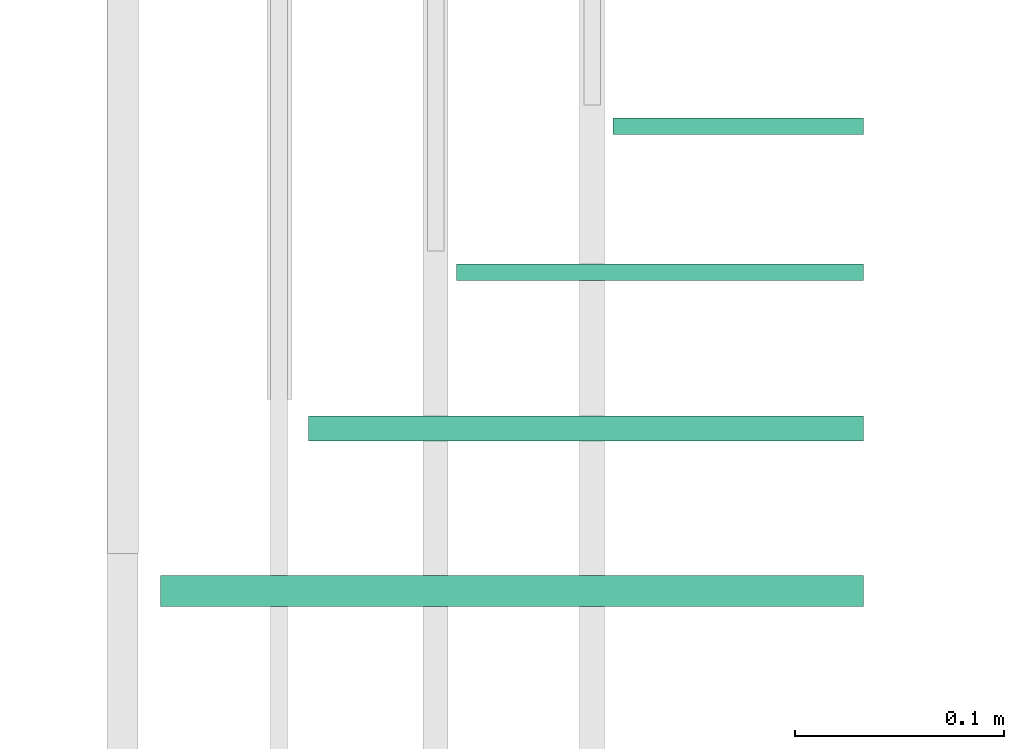
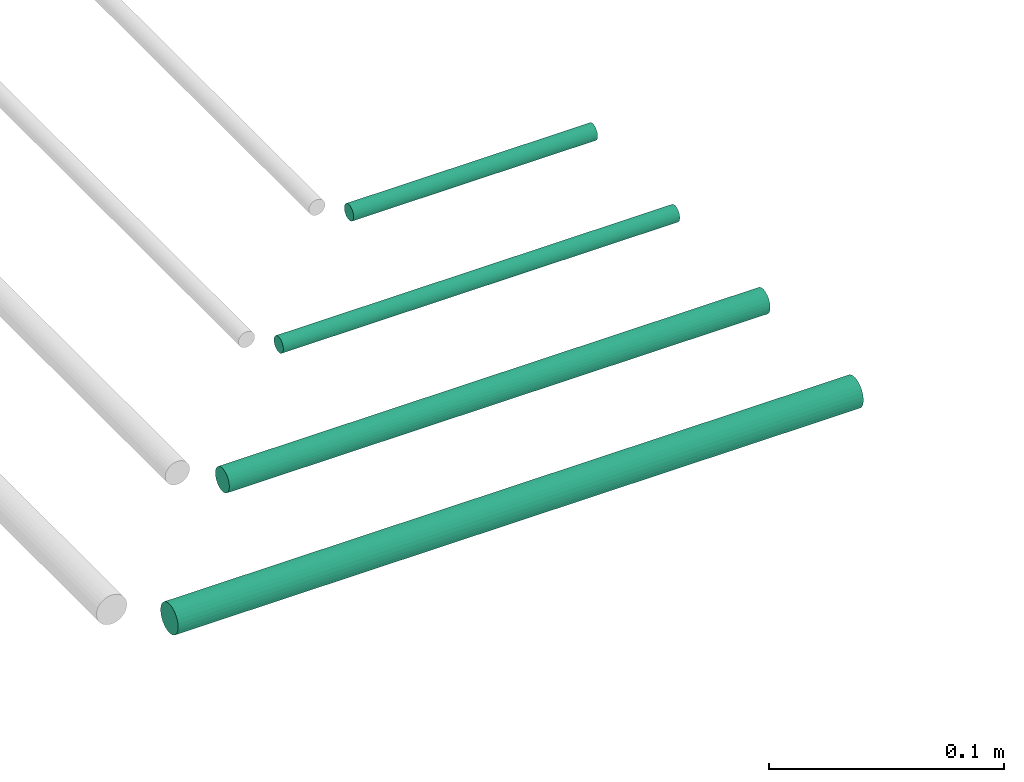
# One storey, part 122 of 331: 4 flow segments.
"""IFC2X3 building model written with IfcOpenShell, lengths in millimetres."""

from ifc_helpers import new_model, entity, si_unit, converted_unit, derived_unit, direction, frame, frame_2d, origin, origin_2d_with_axis, place, context, subcontext, project, spatial, circle, extrude, type_object, element, save


model = new_model("IFC2X3")

# Units and contexts
model_context = context("Model", 3, precision=0.01, world=origin(), true_north=direction((6.12303176911189e-17, 1.0)))
body_context = subcontext(model_context, "Body", "Model", "MODEL_VIEW")
ifc_project = project(units=[si_unit("LENGTHUNIT", "METRE", prefix="MILLI"), si_unit("AREAUNIT", "SQUARE_METRE"), si_unit("VOLUMEUNIT", "CUBIC_METRE"), converted_unit("PLANEANGLEUNIT", "DEGREE", entity("IfcRatioMeasure", 0.0174532925199433), si_unit("PLANEANGLEUNIT", "RADIAN"), dimensions=[0, 0, 0, 0, 0, 0, 0]), si_unit("MASSUNIT", "GRAM", prefix="KILO"), derived_unit("MASSDENSITYUNIT", [(si_unit("MASSUNIT", "GRAM", prefix="KILO"), 1), (si_unit("LENGTHUNIT", "METRE"), -3)]), derived_unit("MOMENTOFINERTIAUNIT", [(si_unit("LENGTHUNIT", "METRE"), 4)]), si_unit("TIMEUNIT", "SECOND"), si_unit("FREQUENCYUNIT", "HERTZ"), si_unit("THERMODYNAMICTEMPERATUREUNIT", "DEGREE_CELSIUS"), derived_unit("THERMALTRANSMITTANCEUNIT", [(si_unit("MASSUNIT", "GRAM", prefix="KILO"), 1), (si_unit("THERMODYNAMICTEMPERATUREUNIT", "KELVIN"), -1), (si_unit("TIMEUNIT", "SECOND"), -3)]), derived_unit("VOLUMETRICFLOWRATEUNIT", [(si_unit("LENGTHUNIT", "METRE"), 3), (si_unit("TIMEUNIT", "SECOND"), -1)]), derived_unit("MASSFLOWRATEUNIT", [(si_unit("MASSUNIT", "GRAM", prefix="KILO"), 1), (si_unit("TIMEUNIT", "SECOND"), -1)]), derived_unit("ROTATIONALFREQUENCYUNIT", [(si_unit("TIMEUNIT", "SECOND"), -1)]), si_unit("ELECTRICCURRENTUNIT", "AMPERE"), si_unit("ELECTRICVOLTAGEUNIT", "VOLT"), si_unit("POWERUNIT", "WATT"), si_unit("FORCEUNIT", "NEWTON", prefix="KILO"), si_unit("ILLUMINANCEUNIT", "LUX"), si_unit("LUMINOUSFLUXUNIT", "LUMEN"), si_unit("LUMINOUSINTENSITYUNIT", "CANDELA"), derived_unit("USERDEFINED", [(si_unit("MASSUNIT", "GRAM", prefix="KILO"), -1), (si_unit("LENGTHUNIT", "METRE"), -2), (si_unit("TIMEUNIT", "SECOND"), 3), (si_unit("LUMINOUSFLUXUNIT", "LUMEN"), 1)]), derived_unit("LINEARVELOCITYUNIT", [(si_unit("LENGTHUNIT", "METRE"), 1), (si_unit("TIMEUNIT", "SECOND"), -1)]), si_unit("PRESSUREUNIT", "PASCAL"), derived_unit("USERDEFINED", [(si_unit("LENGTHUNIT", "METRE"), -2), (si_unit("MASSUNIT", "GRAM", prefix="KILO"), 1), (si_unit("TIMEUNIT", "SECOND"), -2)]), derived_unit("LINEARFORCEUNIT", [(si_unit("MASSUNIT", "GRAM", prefix="KILO"), 1), (si_unit("LENGTHUNIT", "METRE"), 1), (si_unit("TIMEUNIT", "SECOND"), -2), (si_unit("LENGTHUNIT", "METRE"), -1)]), derived_unit("PLANARFORCEUNIT", [(si_unit("MASSUNIT", "GRAM", prefix="KILO"), 1), (si_unit("LENGTHUNIT", "METRE"), 1), (si_unit("TIMEUNIT", "SECOND"), -2), (si_unit("LENGTHUNIT", "METRE"), -2)])], contexts=[model_context])

# Site, building, storey
site_placement = place(None, frame((0.0, -0.00077364408347762, 0.0)))
site = spatial("IfcSite", under=ifc_project, at=site_placement, CompositionType="ELEMENT")
building_placement = place(site_placement, origin())
building = spatial("IfcBuilding", under=site, at=building_placement, CompositionType="ELEMENT")
storey_placement = place(building_placement, origin())
storey = spatial("IfcBuildingStorey", under=building, at=storey_placement, CompositionType="ELEMENT", Elevation=0.0)

# Flow segments
pipe_segment_type = type_object("IfcPipeSegmentType", PredefinedType="NOTDEFINED")
flow_segment_1_placement = place(storey_placement, frame((20856.328927594, 3880.89349484378, 19044.4047277641)))
element("IfcFlowSegment", 1, at=flow_segment_1_placement, inside=storey, type_object=pipe_segment_type, context=body_context, shape_type="SweptSolid", body=[
    extrude(circle(Radius=4.0, at=origin_2d_with_axis()), frame((0.0, 5.59527223591607, 5.59527223591499), z_axis=(1.0, 0.0, 0.0), x_axis=(0.0, -1.0, 0.0)), (0.0, 0.0, 1.0), 120.000000000003),
])
flow_segment_2_placement = place(storey_placement, frame((20781.328927594, 3810.89349484378, 19044.4047277641)))
element("IfcFlowSegment", 2, at=flow_segment_2_placement, inside=storey, type_object=pipe_segment_type, context=body_context, shape_type="SweptSolid", body=[
    extrude(circle(Radius=4.0, at=origin_2d_with_axis()), frame((0.0, 5.59527223591607, 5.59527223591499), z_axis=(1.0, 0.0, 0.0), x_axis=(0.0, -1.0, 0.0)), (0.0, 0.0, 1.0), 195.000000000003),
])
flow_segment_3_placement = place(storey_placement, frame((20710.328927594, 3733.89349484379, 19042.4047277641)))
element("IfcFlowSegment", 3, at=flow_segment_3_placement, inside=storey, type_object=pipe_segment_type, context=body_context, shape_type="SweptSolid", body=[
    extrude(circle(Radius=6.0, at=frame_2d((5.41433564649196e-13, 0.0), x_axis=(1.0, 0.0))), frame((0.0, 7.5952722359167, 7.5952722359167), z_axis=(1.0, 0.0, 0.0), x_axis=(0.0, -1.0, 0.0)), (0.0, 0.0, 1.0), 266.0),
])
flow_segment_4_placement = place(storey_placement, frame((20639.328927594, 3654.52529159145, 19040.9047277641)))
element("IfcFlowSegment", 4, at=flow_segment_4_placement, inside=storey, type_object=pipe_segment_type, context=body_context, shape_type="SweptSolid", body=[
    extrude(circle(Radius=7.5, at=frame_2d((5.41433564649196e-13, 0.0), x_axis=(1.0, 0.0))), frame((0.0, 9.09527223591636, 9.09527223591636), z_axis=(1.0, 0.0, 0.0), x_axis=(0.0, -1.0, 0.0)), (0.0, 0.0, 1.0), 337.000000000001),
])

save(model, "model.ifc")
